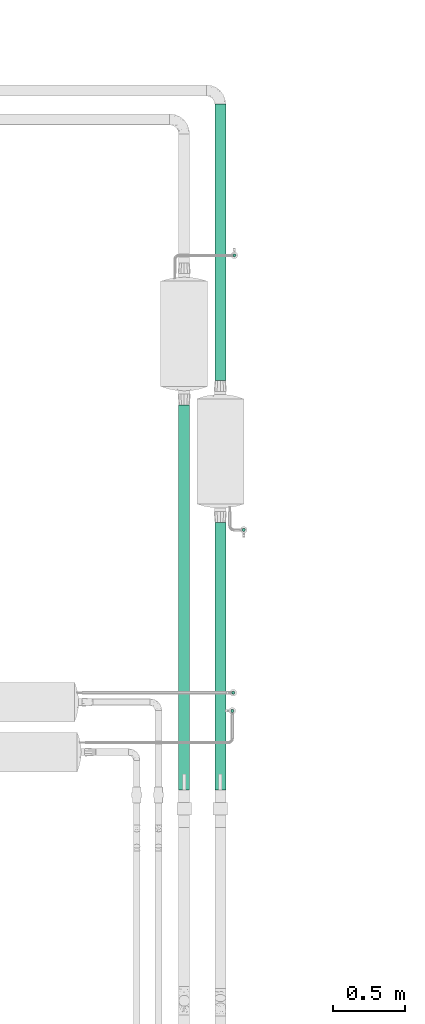
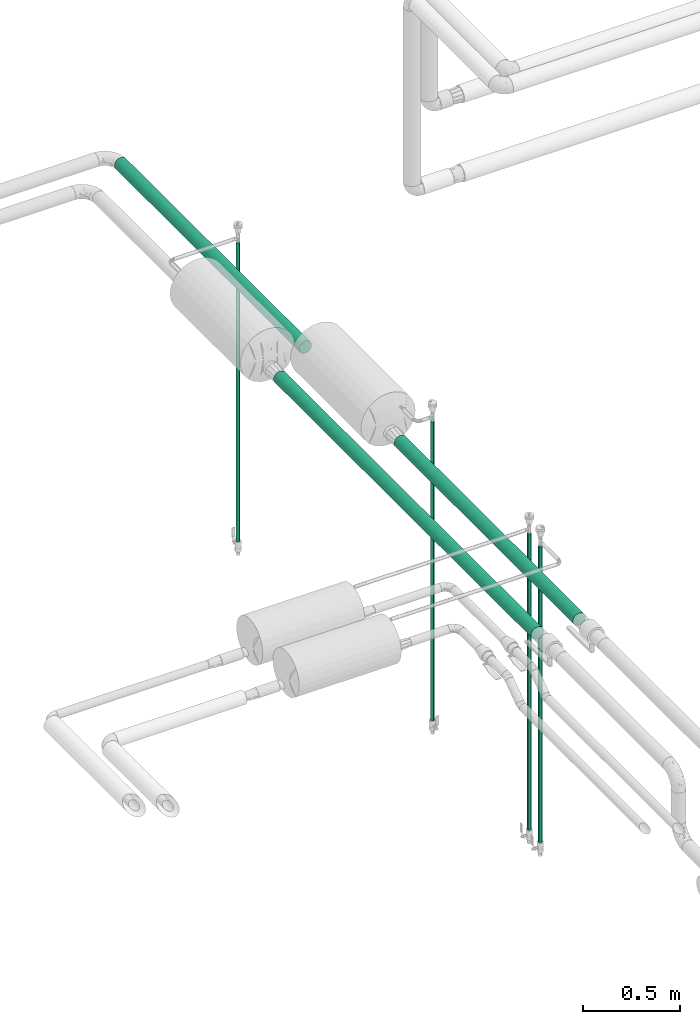
# One storey, part 528 of 827: 7 flow segments.
"""IFC2X3 building model written with IfcOpenShell, lengths in millimetres."""

from ifc_helpers import new_model, entity, si_unit, converted_unit, derived_unit, direction, frame, origin, origin_2d_with_axis, place, context, subcontext, project, spatial, circle, extrude, type_object, element, save


model = new_model("IFC2X3")

# Units and contexts
model_context = context("Model", 3, precision=0.01, world=origin(), true_north=direction((6.12303176911189e-17, 1.0)))
body_context = subcontext(model_context, "Body", "Model", "MODEL_VIEW")
ifc_project = project(units=[si_unit("LENGTHUNIT", "METRE", prefix="MILLI"), si_unit("AREAUNIT", "SQUARE_METRE"), si_unit("VOLUMEUNIT", "CUBIC_METRE"), converted_unit("PLANEANGLEUNIT", "DEGREE", entity("IfcRatioMeasure", 0.0174532925199433), si_unit("PLANEANGLEUNIT", "RADIAN"), dimensions=[0, 0, 0, 0, 0, 0, 0]), si_unit("MASSUNIT", "GRAM", prefix="KILO"), derived_unit("MASSDENSITYUNIT", [(si_unit("MASSUNIT", "GRAM", prefix="KILO"), 1), (si_unit("LENGTHUNIT", "METRE"), -3)]), derived_unit("MOMENTOFINERTIAUNIT", [(si_unit("LENGTHUNIT", "METRE"), 4)]), si_unit("TIMEUNIT", "SECOND"), si_unit("FREQUENCYUNIT", "HERTZ"), si_unit("THERMODYNAMICTEMPERATUREUNIT", "DEGREE_CELSIUS"), derived_unit("THERMALTRANSMITTANCEUNIT", [(si_unit("MASSUNIT", "GRAM", prefix="KILO"), 1), (si_unit("THERMODYNAMICTEMPERATUREUNIT", "KELVIN"), -1), (si_unit("TIMEUNIT", "SECOND"), -3)]), derived_unit("VOLUMETRICFLOWRATEUNIT", [(si_unit("LENGTHUNIT", "METRE"), 3), (si_unit("TIMEUNIT", "SECOND"), -1)]), derived_unit("MASSFLOWRATEUNIT", [(si_unit("MASSUNIT", "GRAM", prefix="KILO"), 1), (si_unit("TIMEUNIT", "SECOND"), -1)]), derived_unit("ROTATIONALFREQUENCYUNIT", [(si_unit("TIMEUNIT", "SECOND"), -1)]), si_unit("ELECTRICCURRENTUNIT", "AMPERE"), si_unit("ELECTRICVOLTAGEUNIT", "VOLT"), si_unit("POWERUNIT", "WATT"), si_unit("FORCEUNIT", "NEWTON", prefix="KILO"), si_unit("ILLUMINANCEUNIT", "LUX"), si_unit("LUMINOUSFLUXUNIT", "LUMEN"), si_unit("LUMINOUSINTENSITYUNIT", "CANDELA"), derived_unit("USERDEFINED", [(si_unit("MASSUNIT", "GRAM", prefix="KILO"), -1), (si_unit("LENGTHUNIT", "METRE"), -2), (si_unit("TIMEUNIT", "SECOND"), 3), (si_unit("LUMINOUSFLUXUNIT", "LUMEN"), 1)]), derived_unit("LINEARVELOCITYUNIT", [(si_unit("LENGTHUNIT", "METRE"), 1), (si_unit("TIMEUNIT", "SECOND"), -1)]), si_unit("PRESSUREUNIT", "PASCAL"), derived_unit("USERDEFINED", [(si_unit("LENGTHUNIT", "METRE"), -2), (si_unit("MASSUNIT", "GRAM", prefix="KILO"), 1), (si_unit("TIMEUNIT", "SECOND"), -2)]), derived_unit("LINEARFORCEUNIT", [(si_unit("MASSUNIT", "GRAM", prefix="KILO"), 1), (si_unit("LENGTHUNIT", "METRE"), 1), (si_unit("TIMEUNIT", "SECOND"), -2), (si_unit("LENGTHUNIT", "METRE"), -1)]), derived_unit("PLANARFORCEUNIT", [(si_unit("MASSUNIT", "GRAM", prefix="KILO"), 1), (si_unit("LENGTHUNIT", "METRE"), 1), (si_unit("TIMEUNIT", "SECOND"), -2), (si_unit("LENGTHUNIT", "METRE"), -2)])], contexts=[model_context])

# Site, building, storey
site_placement = place(None, origin())
site = spatial("IfcSite", under=ifc_project, at=site_placement, CompositionType="ELEMENT")
building_placement = place(site_placement, origin())
building = spatial("IfcBuilding", under=site, at=building_placement, CompositionType="ELEMENT")
storey_placement = place(building_placement, frame((0.0, 0.0, 28200.0)))
storey = spatial("IfcBuildingStorey", under=building, at=storey_placement, Name="08", CompositionType="ELEMENT", Elevation=28200.0)

# Flow segments
pipe_segment_type_1 = type_object("IfcPipeSegmentType", PredefinedType="NOTDEFINED")
flow_segment_1_placement = place(storey_placement, frame((26154.31, 17075.0, 2960.4)))
element("IfcFlowSegment", 1, at=flow_segment_1_placement, inside=storey, type_object=pipe_segment_type_1, context=body_context, shape_type="SweptSolid", body=[
    extrude(circle(Radius=38.0, at=origin_2d_with_axis()), frame((39.6, 0.0, 39.6), z_axis=(0.0, 1.0, 0.0), x_axis=(-1.0, 0.0, 0.0)), (0.0, 0.0, 1.0), 1910.00000000001),
])
flow_segment_2_placement = place(storey_placement, frame((25904.69, 14243.77, 2960.4)))
element("IfcFlowSegment", 2, at=flow_segment_2_placement, inside=storey, type_object=pipe_segment_type_1, context=body_context, shape_type="SweptSolid", body=[
    extrude(circle(Radius=38.0, at=origin_2d_with_axis()), frame((39.6, 0.0, 39.6), z_axis=(5.92492268609707e-07, 1.0, 0.0), x_axis=(-1.0, 5.92492268609707e-07, 0.0)), (0.0, 0.0, 1.0), 2662.52909362043),
])
flow_segment_3_placement = place(storey_placement, frame((26154.31, 14243.77, 2960.4)))
element("IfcFlowSegment", 3, at=flow_segment_3_placement, inside=storey, type_object=pipe_segment_type_1, context=body_context, shape_type="SweptSolid", body=[
    extrude(circle(Radius=38.0, at=origin_2d_with_axis()), frame((39.6, 0.0, 39.6), z_axis=(0.0, 1.0, 0.0), x_axis=(-1.0, 0.0, 0.0)), (0.0, 0.0, 1.0), 1849.22932864636),
])
pipe_segment_type_2 = type_object("IfcPipeSegmentType", PredefinedType="NOTDEFINED")
flow_segment_4_placement = place(storey_placement, frame((26279.11, 17928.03, 1218.83)))
element("IfcFlowSegment", 4, at=flow_segment_4_placement, inside=storey, type_object=pipe_segment_type_2, context=body_context, shape_type="SweptSolid", body=[
    extrude(circle(Radius=10.65, at=origin_2d_with_axis()), frame((12.25, 12.25, 0.0)), (0.0, 0.0, 1.0), 1886.16925284206),
])
flow_segment_5_placement = place(storey_placement, frame((26271.05, 14903.34, 1235.5)))
element("IfcFlowSegment", 5, at=flow_segment_5_placement, inside=storey, type_object=pipe_segment_type_2, context=body_context, shape_type="SweptSolid", body=[
    extrude(circle(Radius=10.65, at=origin_2d_with_axis()), frame((12.25, 12.26, 0.0), z_axis=(0.0, -1.0551437445561e-05, 1.0), x_axis=(-1.0, 0.0, 0.0)), (-2.73864486658759e-09, 0.0, 1.0), 1869.50000010407),
])
flow_segment_6_placement = place(storey_placement, frame((26264.43, 14778.19, 1235.5)))
element("IfcFlowSegment", 6, at=flow_segment_6_placement, inside=storey, type_object=pipe_segment_type_2, context=body_context, shape_type="SweptSolid", body=[
    extrude(circle(Radius=10.65, at=origin_2d_with_axis()), frame((12.25, 12.25, 0.0), z_axis=(0.0, 0.0, 1.0), x_axis=(-1.0, 0.0, 0.0)), (0.0, 0.0, 1.0), 1867.74099338279),
])
flow_segment_7_placement = place(storey_placement, frame((26343.61, 16029.47, 1218.83)))
element("IfcFlowSegment", 7, at=flow_segment_7_placement, inside=storey, type_object=pipe_segment_type_2, context=body_context, shape_type="SweptSolid", body=[
    extrude(circle(Radius=10.65, at=origin_2d_with_axis()), frame((12.25, 12.25, 0.0)), (0.0, 0.0, 1.0), 1886.16925191243),
])

save(model, "model.ifc")
